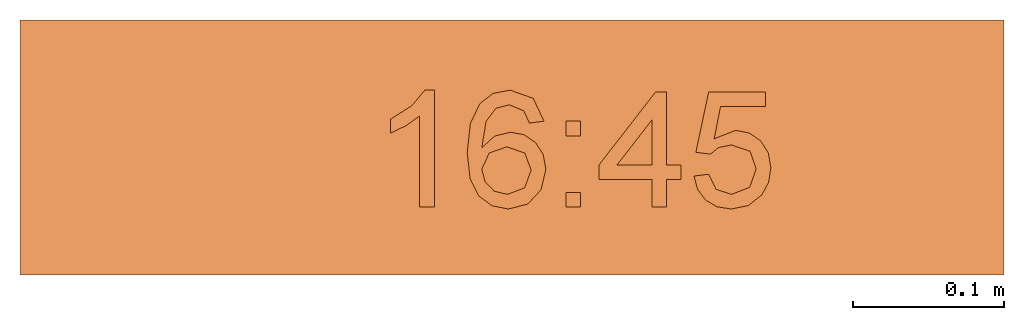
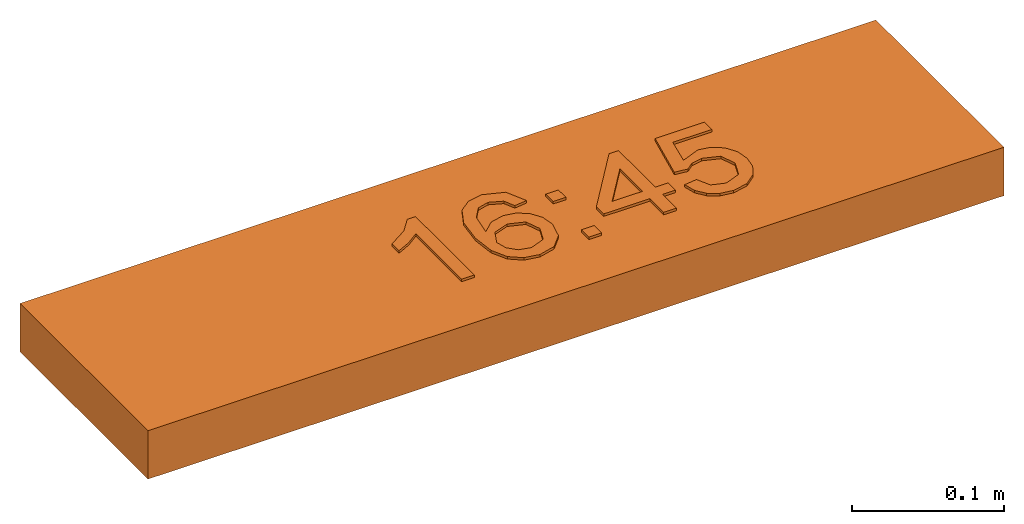
# One storey: 1 proxy.
"""IFC2X3 building model written with IfcOpenShell, lengths in millimetres."""

from ifc_helpers import new_model, entity, si_unit, converted_unit, derived_unit, direction, frame, origin, origin_2d_with_axis, place, context, subcontext, project, spatial, polyline, rectangle, outline, extrude, source, transform, mapped, material, material_list, type_object, type_shapes, element, save


model = new_model("IFC2X3")

# Units and contexts
model_context = context("Model", 3, precision=0.01, world=origin(), true_north=direction((6.12303176911189e-17, 1.0)))
body_context = subcontext(model_context, "Body", "Model", "MODEL_VIEW")
ifc_project = project(units=[si_unit("LENGTHUNIT", "METRE", prefix="MILLI"), si_unit("AREAUNIT", "SQUARE_METRE"), si_unit("VOLUMEUNIT", "CUBIC_METRE"), converted_unit("PLANEANGLEUNIT", "DEGREE", entity("IfcRatioMeasure", 0.0174532925199433), si_unit("PLANEANGLEUNIT", "RADIAN"), dimensions=[0, 0, 0, 0, 0, 0, 0]), si_unit("MASSUNIT", "GRAM", prefix="KILO"), derived_unit("MASSDENSITYUNIT", [(si_unit("MASSUNIT", "GRAM", prefix="KILO"), 1), (si_unit("LENGTHUNIT", "METRE"), -3)]), derived_unit("MOMENTOFINERTIAUNIT", [(si_unit("LENGTHUNIT", "METRE"), 4)]), si_unit("TIMEUNIT", "SECOND"), si_unit("FREQUENCYUNIT", "HERTZ"), si_unit("THERMODYNAMICTEMPERATUREUNIT", "DEGREE_CELSIUS"), derived_unit("THERMALTRANSMITTANCEUNIT", [(si_unit("MASSUNIT", "GRAM", prefix="KILO"), 1), (si_unit("THERMODYNAMICTEMPERATUREUNIT", "KELVIN"), -1), (si_unit("TIMEUNIT", "SECOND"), -3)]), derived_unit("VOLUMETRICFLOWRATEUNIT", [(si_unit("LENGTHUNIT", "METRE"), 3), (si_unit("TIMEUNIT", "SECOND"), -1)]), derived_unit("MASSFLOWRATEUNIT", [(si_unit("MASSUNIT", "GRAM", prefix="KILO"), 1), (si_unit("TIMEUNIT", "SECOND"), -1)]), derived_unit("ROTATIONALFREQUENCYUNIT", [(si_unit("TIMEUNIT", "SECOND"), -1)]), si_unit("ELECTRICCURRENTUNIT", "AMPERE"), si_unit("ELECTRICVOLTAGEUNIT", "VOLT"), si_unit("POWERUNIT", "WATT"), si_unit("FORCEUNIT", "NEWTON", prefix="KILO"), si_unit("ILLUMINANCEUNIT", "LUX"), si_unit("LUMINOUSFLUXUNIT", "LUMEN"), si_unit("LUMINOUSINTENSITYUNIT", "CANDELA"), derived_unit("USERDEFINED", [(si_unit("MASSUNIT", "GRAM", prefix="KILO"), -1), (si_unit("LENGTHUNIT", "METRE"), -2), (si_unit("TIMEUNIT", "SECOND"), 3), (si_unit("LUMINOUSFLUXUNIT", "LUMEN"), 1)]), derived_unit("LINEARVELOCITYUNIT", [(si_unit("LENGTHUNIT", "METRE"), 1), (si_unit("TIMEUNIT", "SECOND"), -1)]), si_unit("PRESSUREUNIT", "PASCAL"), derived_unit("USERDEFINED", [(si_unit("LENGTHUNIT", "METRE"), -2), (si_unit("MASSUNIT", "GRAM", prefix="KILO"), 1), (si_unit("TIMEUNIT", "SECOND"), -2)]), derived_unit("LINEARFORCEUNIT", [(si_unit("MASSUNIT", "GRAM", prefix="KILO"), 1), (si_unit("LENGTHUNIT", "METRE"), 1), (si_unit("TIMEUNIT", "SECOND"), -2), (si_unit("LENGTHUNIT", "METRE"), -1)]), derived_unit("PLANARFORCEUNIT", [(si_unit("MASSUNIT", "GRAM", prefix="KILO"), 1), (si_unit("LENGTHUNIT", "METRE"), 1), (si_unit("TIMEUNIT", "SECOND"), -2), (si_unit("LENGTHUNIT", "METRE"), -2)])], contexts=[model_context])

# Site, building, storey
site_placement = place(None, frame((0.0, -0.00077364408347762, 0.0)))
site = spatial("IfcSite", under=ifc_project, at=site_placement, CompositionType="ELEMENT")
building_placement = place(site_placement, origin())
building = spatial("IfcBuilding", under=site, at=building_placement, CompositionType="ELEMENT")
storey_placement = place(building_placement, frame((0.0, 0.0, -4200.0)))
storey = spatial("IfcBuildingStorey", under=building, at=storey_placement, CompositionType="ELEMENT", Elevation=-4200.0)

# Proxy
ifc_material_1 = material()
ifc_material_2 = material()
ifc_material_list_1 = material_list([ifc_material_1, ifc_material_2])
ifc_material_list_2 = material_list([ifc_material_1, ifc_material_1, ifc_material_1, ifc_material_1, ifc_material_1, ifc_material_1, ifc_material_2])
building_element_proxy_type = type_object("IfcBuildingElementProxyType", PredefinedType="NOTDEFINED", material=ifc_material_list_2)
shared_shape = source(origin(), body_context, "Body", "SweptSolid", [
    extrude(outline(polyline([(-49.3297558922559, -13.0650252525253), (28.2460016835017, -13.0650252525253), (28.2460016835017, -6.81502525252525), (17.924031986532, 1.81186868686869), (8.85206228956228, 16.0258838383838), (-0.314604377104382, 16.0258838383838), (4.58122895622896, 5.8175505050505), (11.1247895622896, -3.36805555555555), (-49.3297558922559, -3.36805555555555), (-49.3297558922559, -13.0650252525253)])), frame((-64.5801773123525, 9.80013072699887, 39.0), z_axis=(0.0, 0.0, 1.0), x_axis=(0.0, 1.0, 0.0)), (0.0, 0.0, 1.0), 2.0),
    extrude(outline(polyline([(2.24011853050057, -27.5618774069986), (18.9807108648058, -27.5618774069986), (30.4808593810603, -16.0523867195033), (33.2951509700614, -4.93311916754034), (31.0144130646924, 5.7575762787575), (21.7987736055003, 17.1572643136776), (5.24761200604798, 27.3340921309932), (-11.0974111566595, 32.9532554648861), (-23.9746782077303, 32.7048013849557), (-33.6281248088369, 27.5788768374718), (-40.3016866216521, 18.5656287687041), (-42.7660378318467, 5.67274679265255), (-37.9721755114974, -6.33783567611335), (-27.2455737728681, -14.9533745518323), (-17.5348420919177, -17.6670021030155), (-8.19356542843746, -16.4449721815935), (-0.291454529980238, -11.8654762653203), (5.1017798559014, -4.50670583194971), (7.34785423483786, 6.15330079609256), (4.01114564454941, 17.1916653593814), (18.4548387600492, 7.30997301607691), (23.5935364768699, -2.44380014762508), (21.9745124884661, -11.3576456930974), (14.1729209955885, -18.4151203904576), (5.29132308249511, -18.2779876016039), (2.24011853050057, -27.5618774069986)]), holes=[polyline([(-8.96594443465761, 23.331014608368), (-1.26018519149069, 14.3532201865936), (-2.5541294758174, 1.98565321334379), (-11.3601436525543, -6.99563380914675), (-23.3897211552763, -6.05015679749623), (-32.1796543698203, 2.91675270916293), (-31.2121825444575, 15.1035400981067), (-25.5825280165424, 22.1095150051529), (-17.5185200759943, 24.8943605417974), (-8.96594443465761, 23.331014608368)])]), frame((-2.74431872649391, 3.62832938019752, 39.0), z_axis=(0.0, 0.0, 1.0), x_axis=(-0.427648602040224, 0.903945060926294, 0.0)), (0.0, 0.0, 1.0), 2.0),
    extrude(rectangle(XDim=9.6969696969697, YDim=9.6969696969697, at=origin_2d_with_axis()), frame((40.6060600613849, -34.6811403167722, 39.0)), (0.0, 0.0, 1.0), 2.0),
    extrude(rectangle(XDim=9.6969696969697, YDim=9.6969696969697, at=origin_2d_with_axis()), frame((40.6060600613849, 12.5915869559551, 39.0)), (0.0, 0.0, 1.0), 2.0),
    extrude(outline(polyline([(-0.881542699724549, -28.099173553719), (8.81542699724518, -28.099173553719), (8.81542699724518, -9.91735537190083), (18.5123966942148, -9.91735537190083), (18.5123966942148, -0.220385674931129), (8.81542699724518, -0.220385674931129), (8.81542699724518, 48.2644628099173), (1.54269972451788, 48.2644628099173), (-36.0330578512397, -0.220385674931129), (-36.0330578512397, -9.91735537190083), (-0.881542699724549, -9.91735537190083), (-0.881542699724549, -28.099173553719)]), holes=[polyline([(-0.881542699724549, -0.220385674931129), (-24.1012396694215, -0.220385674931129), (-0.881542699724549, 29.7417355371901), (-0.881542699724549, -0.220385674931129)])]), frame((93.6088148823215, -11.430451611538, 39.0)), (0.0, 0.0, 1.0), 2.0),
    extrude(outline(polyline([(3.28300438653322, -28.2688849771477), (12.486486021848, -28.2688849771477), (20.5381191721727, -25.0278768228724), (26.8189712884816, -18.8467250057334), (30.7101098217491, -10.0262940171423), (31.3981318926443, 1.60805822132837), (26.9015703293825, 11.8381634310008), (20.0564059210334, 18.3764186541994), (11.0756486569987, 22.3371351079238), (1.04176214713842, 23.2585538509025), (-7.93780091536274, 20.406367606958), (-14.9085866775867, 14.4772629545935), (-18.9161412866151, 6.16792647231239), (-17.143675825551, -8.98191514451195), (-36.7240258370804, 0.516426480877832), (-29.0829385906137, 29.2527275669393), (-38.4542673524376, 31.7445980575068), (-48.1102655033866, -4.56930089456074), (-11.6339210401096, -23.0481793347475), (-7.97063445431417, -13.9883343842446), (-10.7994707393594, -7.60185176247611), (-10.2407841657114, 1.05867314396988), (-3.00292415200101, 11.8430863913258), (9.16948621404518, 12.8100644404395), (19.9796079835536, 5.44778336414573), (21.348514929029, -7.49781677359889), (15.5141589936472, -16.4311092462368), (4.60345878187273, -18.5860724040029), (3.28300438653322, -28.2688849771477)])), frame((147.081979974805, -8.48643658300594, 39.0), z_axis=(0.0, 0.0, 1.0), x_axis=(0.256974144339772, -0.966418278563088, 0.0)), (0.0, 0.0, 1.0), 2.0),
    extrude(rectangle(XDim=652.0, YDim=169.000000000001, at=origin_2d_with_axis()), frame((0.0, 0.0, 0.0), z_axis=(0.0, 0.0, 1.0), x_axis=(-1.0, 0.0, 0.0)), (0.0, 0.0, 1.0), 38.9999999999999),
])
type_shapes(building_element_proxy_type, [shared_shape])
proxy_placement = place(storey_placement, frame((51787.7328015248, 25711.1720113589, 0.0)))
element("IfcBuildingElementProxy", 1, at=proxy_placement, inside=storey, type_object=building_element_proxy_type, material=ifc_material_list_1, context=body_context, shape_type="MappedRepresentation", body=[
    mapped(shared_shape, transform((0.0, 0.0, 0.0), scale=1.0)),
])

save(model, "model.ifc")
